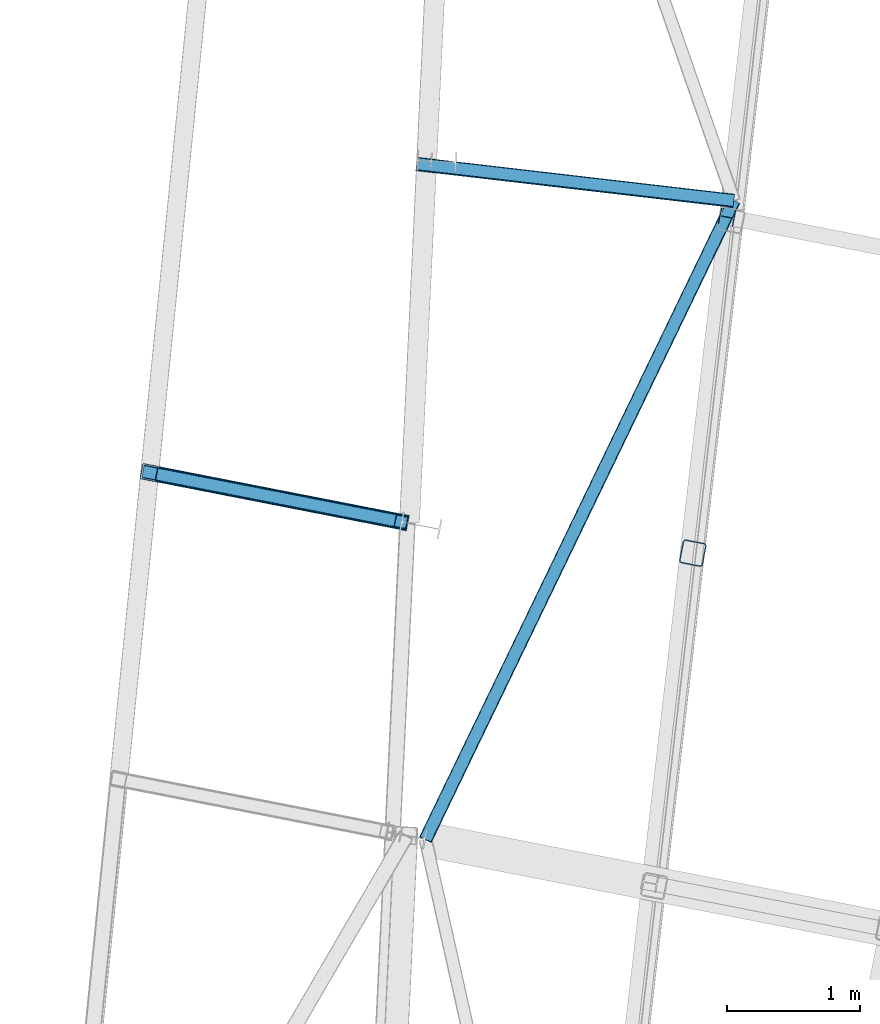
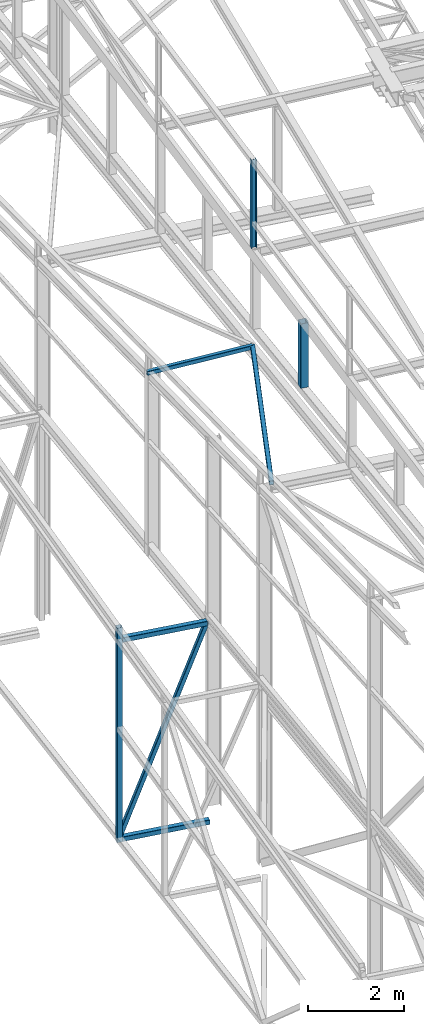
# One storey, part 67 of 215: 7 beams, 1 member, 8 elements without a shape of their own.
"""IFC2X3 building model written with IfcOpenShell, lengths in millimetres."""

import ifcopenshell
import ifcopenshell.guid

model = None  # the IFC model being written
_history = None  # IfcOwnerHistory: only IFC2X3 demands one
_inside = {}  # id of a spatial element -> (the spatial element, [elements in it])
_under = {}  # id of a project, library or spatial element -> (it, [spatial elements below it])
_declared = {}  # id of a project -> (the project, [libraries it declares])
_typed = {}  # id of a type object -> (the type object, [elements of that type])
_made_of = {}  # id of a material, layer set ... -> (it, [elements and type objects made of it])


def new_model(schema):
    """Start an empty IFC model of exactly this schema.

    Asked for "IFC4X3", IfcOpenShell would pick the latest addendum, in which some entities
    have other attributes; the version numbers below select the first issue.
    IFC2X3 requires an IfcOwnerHistory on every rooted entity: one is made here for all.
    """
    global model, _history
    if schema == "IFC4X3":
        model = ifcopenshell.file(schema_version=(4, 3, 0, 0))
    else:
        model = ifcopenshell.file(schema=schema)
    _inside.clear()
    _under.clear()
    _declared.clear()
    _typed.clear()
    _made_of.clear()
    _history = None
    if model.schema == "IFC2X3":
        org = make("IfcOrganization", Name="unknown")
        user = make(
            "IfcPersonAndOrganization",
            ThePerson=make("IfcPerson", FamilyName="unknown"),
            TheOrganization=org,
        )
        app = make(
            "IfcApplication",
            ApplicationDeveloper=org,
            Version="unknown",
            ApplicationFullName="unknown",
            ApplicationIdentifier="unknown",
        )
        _history = make(
            "IfcOwnerHistory",
            OwningUser=user,
            OwningApplication=app,
            ChangeAction="ADDED",
            CreationDate=0,
        )
    return model


def make(cls, **values):
    """One entity of the class cls with the attributes given. An attribute that is None is left unset."""
    return model.create_entity(
        cls, **{name: value for name, value in values.items() if value is not None}
    )


def rooted(cls, **values):
    """An entity with a GlobalId (a new one), such as an element, a storey or a relation."""
    return make(cls, GlobalId=ifcopenshell.guid.new(), OwnerHistory=_history, **values)


def si_unit(unit_type, name, prefix=None):
    """IfcSIUnit, for example si_unit("LENGTHUNIT", "METRE", prefix="MILLI")."""
    return make("IfcSIUnit", UnitType=unit_type, Prefix=prefix, Name=name)


def assignment(units):
    """IfcUnitAssignment: the units of a project."""
    return None if units is None else make("IfcUnitAssignment", Units=units)


def point(xyz):
    """IfcCartesianPoint."""
    return None if xyz is None else make("IfcCartesianPoint", Coordinates=xyz)


def direction(xyz):
    """IfcDirection."""
    return None if xyz is None else make("IfcDirection", DirectionRatios=xyz)


def frame(location, z_axis=None, x_axis=None):
    """IfcAxis2Placement3D, a coordinate frame: its origin and axes. An axis left out is left unset."""
    return make(
        "IfcAxis2Placement3D",
        Location=point(location),
        Axis=direction(z_axis),
        RefDirection=direction(x_axis),
    )


def frame_2d(location, x_axis=None):
    """IfcAxis2Placement2D, a coordinate frame in the plane: its origin and x axis."""
    return make(
        "IfcAxis2Placement2D", Location=point(location), RefDirection=direction(x_axis)
    )


def origin_with_axes():
    """The frame at (0, 0, 0) with the z axis (0, 0, 1) and the x axis (1, 0, 0) written out."""
    return frame((0.0, 0.0, 0.0), z_axis=(0.0, 0.0, 1.0), x_axis=(1.0, 0.0, 0.0))


def origin_2d_with_axis():
    """The frame at (0, 0) in the plane with the x axis (1, 0) written out."""
    return frame_2d((0.0, 0.0), x_axis=(1.0, 0.0))


def place(relative_to, where):
    """IfcLocalPlacement: puts the frame where relative to a parent placement (None: the world)."""
    return make(
        "IfcLocalPlacement", PlacementRelTo=relative_to, RelativePlacement=where
    )


def context(
    kind, dimensions, precision=None, world=None, true_north=None, identifier=None
):
    """IfcGeometricRepresentationContext, for example the 3D "Model" context."""
    return make(
        "IfcGeometricRepresentationContext",
        ContextIdentifier=identifier,
        ContextType=kind,
        CoordinateSpaceDimension=dimensions,
        Precision=precision,
        WorldCoordinateSystem=world,
        TrueNorth=true_north,
    )


def subcontext(parent, identifier, kind, view, scale=None):
    """IfcGeometricRepresentationSubContext, for example "Body" below "Model"."""
    return make(
        "IfcGeometricRepresentationSubContext",
        ContextIdentifier=identifier,
        ContextType=kind,
        ParentContext=parent,
        TargetScale=scale,
        TargetView=view,
    )


def project(units=None, contexts=None):
    """IfcProject with its units and contexts."""
    return rooted(
        "IfcProject",
        Name="project",
        RepresentationContexts=contexts,
        UnitsInContext=assignment(units),
    )


def spatial(cls, under=None, at=None, **own):
    """A site, building, storey or space (cls), placed at a placement, below another one or the project."""
    s = rooted(cls, ObjectPlacement=at, **own)
    if under is not None:
        _under.setdefault(under.id(), (under, []))[1].append(s)
    return s


def profile(cls, at=None, kind="AREA", **sizes):
    """A parametric profile (cls). Its sizes go by their IFC names, for example OverallWidth=200.0."""
    return make(cls, ProfileType=kind, Position=at, **sizes)


def hollow_rectangle(**sizes):
    """IfcRectangleHollowProfileDef."""
    return profile("IfcRectangleHollowProfileDef", **sizes)


def i_section(**sizes):
    """IfcIShapeProfileDef."""
    return profile("IfcIShapeProfileDef", **sizes)


def extrude(swept, where, along, depth):
    """IfcExtrudedAreaSolid: the profile swept, set in the frame where, extruded along a direction by depth."""
    return make(
        "IfcExtrudedAreaSolid",
        SweptArea=swept,
        Position=where,
        ExtrudedDirection=direction(along),
        Depth=depth,
    )


def clip(a, b, op="DIFFERENCE"):
    """IfcBooleanClippingResult: the solid a cut by the half space b."""
    return make(
        "IfcBooleanClippingResult", Operator=op, FirstOperand=a, SecondOperand=b
    )


def halfspace(plane, agree):
    """IfcHalfSpaceSolid: all space on one side of the plane z = 0 of the frame plane."""
    return make(
        "IfcHalfSpaceSolid",
        BaseSurface=make("IfcPlane", Position=plane),
        AgreementFlag=agree,
    )


def shape(context_of_items, identifier, shape_type, items):
    """IfcShapeRepresentation: the items that make up one representation, for example the "Body"."""
    return make(
        "IfcShapeRepresentation",
        ContextOfItems=context_of_items,
        RepresentationIdentifier=identifier,
        RepresentationType=shape_type,
        Items=items,
    )


def material(Name=None, Category=None):
    """IfcMaterial."""
    return make("IfcMaterial", Name=Name, Category=Category)


def made_of(thing, what):
    """Note that an element or type object is made of a material, layer set ...; save() writes the relation."""
    if what is not None:
        _made_of.setdefault(what.id(), (what, []))[1].append(thing)
    return thing


def type_object(cls, material=None, **own):
    """A type object (cls), such as IfcWallType, which elements share."""
    return made_of(rooted(cls, **own), material)


def element(
    cls,
    number,
    at=None,
    inside=None,
    cuts=None,
    type_object=None,
    material=None,
    context=None,
    identifier="Body",
    shape_type=None,
    held_by="IfcProductDefinitionShape",
    body=None,
    shapes=None,
    **own,
):
    """One element of the class cls, such as IfcWall. Its Tag is "e" and its number.

    at: its placement. inside: the storey or other place that contains it. cuts: it is an
    opening in that element (IfcRelVoidsElement). A single representation is given by context,
    identifier, shape_type and body (its items); several are given by shapes. held_by: the class
    of the entity that holds the representations. save() writes the other relations.
    """
    e = rooted(cls, Tag="e%d" % number, ObjectPlacement=at, **own)
    if body is not None:
        shapes = [shape(context, identifier, shape_type, body)]
    if shapes is not None:
        e.Representation = make(held_by, Representations=shapes)
    if inside is not None:
        _inside.setdefault(inside.id(), (inside, []))[1].append(e)
    if cuts is not None:
        rooted(
            "IfcRelVoidsElement", RelatingBuildingElement=cuts, RelatedOpeningElement=e
        )
    if type_object is not None:
        _typed.setdefault(type_object.id(), (type_object, []))[1].append(e)
    return made_of(e, material)


def aggregate(whole, parts):
    """IfcRelAggregates: a whole, such as a stair, and the parts it consists of."""
    return rooted("IfcRelAggregates", RelatingObject=whole, RelatedObjects=parts)


def save(model, path):
    """Write the relations noted so far, then the file.

    IfcRelAggregates (storeys below a building ...), IfcRelContainedInSpatialStructure (elements
    in a storey), IfcRelDefinesByType, IfcRelAssociatesMaterial and IfcRelDeclares: one each for
    every whole, place, type object, material and project.
    """
    for whole, parts in _under.values():
        aggregate(whole, parts)
    for where, things in _inside.values():
        rooted(
            "IfcRelContainedInSpatialStructure",
            RelatedElements=things,
            RelatingStructure=where,
        )
    for kind, things in _typed.values():
        rooted("IfcRelDefinesByType", RelatedObjects=things, RelatingType=kind)
    for what, things in _made_of.values():
        rooted("IfcRelAssociatesMaterial", RelatedObjects=things, RelatingMaterial=what)
    for by, libraries in _declared.values():
        rooted("IfcRelDeclares", RelatingContext=by, RelatedDefinitions=libraries)
    model.write(path)


model = new_model("IFC2X3")

# Units and contexts
model_context = context("Model", 3, precision=1e-05, world=origin_with_axes())
body_context = subcontext(model_context, "Body", "Model", "MODEL_VIEW")
ifc_project = project(units=[si_unit("LENGTHUNIT", "METRE", prefix="MILLI"), si_unit("AREAUNIT", "SQUARE_METRE"), si_unit("VOLUMEUNIT", "CUBIC_METRE"), si_unit("MASSUNIT", "GRAM", prefix="KILO"), si_unit("TIMEUNIT", "SECOND"), si_unit("PLANEANGLEUNIT", "RADIAN"), si_unit("SOLIDANGLEUNIT", "STERADIAN"), si_unit("THERMODYNAMICTEMPERATUREUNIT", "DEGREE_CELSIUS"), si_unit("LUMINOUSINTENSITYUNIT", "LUMEN")], contexts=[model_context])

# Site, building, storey
site_placement = place(None, origin_with_axes())
site = spatial("IfcSite", under=ifc_project, at=site_placement, CompositionType="ELEMENT")
building_placement = place(site_placement, origin_with_axes())
building = spatial("IfcBuilding", under=site, at=building_placement, Name="Undefined", CompositionType="ELEMENT")
storey_placement = place(building_placement, origin_with_axes())
storey = spatial("IfcBuildingStorey", under=building, at=storey_placement, Name="Undefined", CompositionType="ELEMENT", Elevation=0.0)

# Assembly, beam
assembly_1_placement = place(storey_placement, origin_with_axes())
assembly_1 = element("IfcElementAssembly", 1, at=assembly_1_placement, inside=storey, Name="Steel Assembly", AssemblyPlace="NOTDEFINED", PredefinedType="RIGID_FRAME")
ifc_material = material(Name="STEEL/S275JR")
beam_type_1 = type_object("IfcBeamType", PredefinedType="NOTDEFINED")
beam_1_placement = place(assembly_1_placement, frame((36250.7928809844, 36894.7018046411, 5021.75625029921), z_axis=(-0.981422412140383, 0.191859451027444, 0.0), x_axis=(3.7800000005755e-07, 1.94399999970995e-06, -0.999999999998039)))
beam_1 = element("IfcBeam", 2, at=beam_1_placement, type_object=beam_type_1, material=ifc_material, Name="MONTANT", context=body_context, shape_type="SweptSolid", body=[
    extrude(hollow_rectangle(XDim=120.0, YDim=120.0, WallThickness=5.0, InnerFilletRadius=5.0, OuterFilletRadius=10.0, at=origin_2d_with_axis()), frame((5457.13475754329, -2.31118646862289e-18, -3.63797846628199e-12), z_axis=(-1.0, 0.0, 0.0), x_axis=(-6.93889390390723e-18, -1.0, -3.46944695195361e-18)), (0.0, 0.0, 1.0), 5457.1),
])
aggregate(assembly_1, [beam_1])

assembly_2_placement = place(storey_placement, origin_with_axes())
assembly_2 = element("IfcElementAssembly", 3, at=assembly_2_placement, inside=storey, Name="Steel Assembly", AssemblyPlace="NOTDEFINED", PredefinedType="RIGID_FRAME")
beam_2_placement = place(assembly_2_placement, frame((36309.6787913867, 36883.1906591495, 4690.29321998795), z_axis=(0.0, 0.0, 1.0), x_axis=(0.981420896076704, -0.191867206014994, 0.0)))
beam_2 = element("IfcBeam", 4, at=beam_2_placement, type_object=beam_type_1, material=ifc_material, Name="POUTRE", context=body_context, shape_type="SweptSolid", body=[
    extrude(hollow_rectangle(XDim=120.0, YDim=120.0, WallThickness=5.0, InnerFilletRadius=5.0, OuterFilletRadius=10.0, at=origin_2d_with_axis()), frame((1871.77856512388, 0.0, 0.0), z_axis=(-1.0, 0.0, 0.0), x_axis=(-6.93889390390723e-18, -1.0, -3.46944695195361e-18)), (0.0, 0.0, 1.0), 1871.8),
])
aggregate(assembly_2, [beam_2])

assembly_3_placement = place(storey_placement, origin_with_axes())
assembly_3 = element("IfcElementAssembly", 5, at=assembly_3_placement, inside=storey, Name="Steel Assembly", AssemblyPlace="NOTDEFINED", PredefinedType="RIGID_FRAME")
beam_3_placement = place(assembly_3_placement, frame((36309.6798461953, 36883.1985792828, -375.378507595192), z_axis=(0.0, 0.0, 1.0), x_axis=(0.981422409205525, -0.19185946604018, 1.89999991602007e-08)))
beam_3 = element("IfcBeam", 6, at=beam_3_placement, type_object=beam_type_1, material=ifc_material, Name="POUTRE", context=body_context, shape_type="SweptSolid", body=[
    extrude(hollow_rectangle(XDim=120.0, YDim=120.0, WallThickness=5.0, InnerFilletRadius=5.0, OuterFilletRadius=10.0, at=origin_2d_with_axis()), frame((1924.31509716234, 5.34104731875857e-14, 5.6843418860808e-14), z_axis=(-1.0, 0.0, 0.0), x_axis=(-6.93889390390723e-18, -1.0, -3.46944695195361e-18)), (0.0, 0.0, 1.0), 1924.3),
])
aggregate(assembly_3, [beam_3])

assembly_4_placement = place(storey_placement, origin_with_axes())
assembly_4 = element("IfcElementAssembly", 7, at=assembly_4_placement, inside=storey, Name="Steel Assembly", AssemblyPlace="NOTDEFINED", PredefinedType="RIGID_FRAME")
beam_type_2 = type_object("IfcBeamType", PredefinedType="NOTDEFINED")
beam_4_placement = place(assembly_4_placement, frame((38262.259027407, 39216.0740032617, 9368.14621177728), z_axis=(0.115203788960212, 0.992088860657365, -0.0498776459827747), x_axis=(0.993325216792512, -0.115347360975905, -6.30000004858045e-08)))
beam_4 = element("IfcBeam", 8, at=beam_4_placement, type_object=beam_type_2, material=ifc_material, context=body_context, shape_type="SweptSolid", body=[
    extrude(hollow_rectangle(XDim=100.0, YDim=100.0, WallThickness=5.0, InnerFilletRadius=5.0, OuterFilletRadius=10.0, at=origin_2d_with_axis()), frame((2403.47614066428, -1.81713378225441e-12, 3.34853861177903e-14), z_axis=(-1.0, 0.0, 0.0), x_axis=(-6.93889390390723e-18, -1.0, -3.46944695195361e-18)), (0.0, 0.0, 1.0), 2403.5),
])
aggregate(assembly_4, [beam_4])

assembly_5_placement = place(storey_placement, origin_with_axes())
assembly_5 = element("IfcElementAssembly", 9, at=assembly_5_placement, inside=storey, Name="Steel Assembly", AssemblyPlace="NOTDEFINED", PredefinedType="RIGID_FRAME")
beam_5_placement = place(assembly_5_placement, frame((40649.6922643613, 38938.8374652992, 9368.14615700809), z_axis=(0.900788612590412, -0.433950403802687, 0.0163377619925705), x_axis=(-0.434219730893964, -0.899573436780325, 0.047125970988492)))
beam_5 = element("IfcBeam", 10, at=beam_5_placement, type_object=beam_type_2, material=ifc_material, context=body_context, shape_type="SweptSolid", body=[
    extrude(hollow_rectangle(XDim=100.0, YDim=100.0, WallThickness=5.0, InnerFilletRadius=5.0, OuterFilletRadius=10.0, at=origin_2d_with_axis()), frame((5342.99829990424, -3.70744983317921e-14, 4.69224119511743e-14), z_axis=(-1.0, 0.0, 0.0), x_axis=(-6.93889390390723e-18, -1.0, -3.46944695195361e-18)), (0.0, 0.0, 1.0), 5343.0),
])
aggregate(assembly_5, [beam_5])

# Assembly, member
assembly_6_placement = place(storey_placement, origin_with_axes())
assembly_6 = element("IfcElementAssembly", 11, at=assembly_6_placement, inside=storey, Name="Steel Assembly", AssemblyPlace="NOTDEFINED", PredefinedType="RIGID_FRAME")
member_type = type_object("IfcMemberType", PredefinedType="NOTDEFINED")
member_placement = place(assembly_6_placement, frame((36250.7948899859, 36894.7121336176, -345.378507585387), z_axis=(-0.916421876484706, 0.179150003899269, 0.357877381798769), x_axis=(0.351228357938975, -0.0686648469880693, 0.933768589837759)))
member = element("IfcMember", 12, at=member_placement, type_object=member_type, material=ifc_material, Name="POUTRE", context=body_context, shape_type="SweptSolid", body=[
    extrude(hollow_rectangle(XDim=100.0, YDim=100.0, WallThickness=5.0, InnerFilletRadius=5.0, OuterFilletRadius=10.0, at=origin_2d_with_axis()), frame((5397.85477917826, -3.28143983663216e-14, -3.63797880709171e-12), z_axis=(-1.0, 0.0, 0.0), x_axis=(-6.93889390390723e-18, -1.0, -3.46944695195361e-18)), (0.0, 0.0, 1.0), 5397.9),
])
aggregate(assembly_6, [member])

# Assembly, beam
assembly_7_placement = place(storey_placement, origin_with_axes())
assembly_7 = element("IfcElementAssembly", 13, at=assembly_7_placement, inside=storey, Name="Steel Assembly", AssemblyPlace="NOTDEFINED", PredefinedType="RIGID_FRAME")
beam_type_3 = type_object("IfcBeamType", PredefinedType="NOTDEFINED")
beam_6_placement = place(assembly_7_placement, frame((40341.6452446604, 36288.1287499349, 11724.6191089981), z_axis=(-0.981422412140383, 0.191859451027444, 0.0), x_axis=(0.0, 0.0, -1.0)))
beam_6 = element("IfcBeam", 14, at=beam_6_placement, type_object=beam_type_3, material=ifc_material, Name="MONTANT", context=body_context, shape_type="Clipping", body=[
    clip(extrude(hollow_rectangle(XDim=180.0, YDim=180.0, WallThickness=8.0, InnerFilletRadius=12.0, OuterFilletRadius=20.0, at=origin_2d_with_axis()), frame((1644.53155775925, 0.0, 0.0), z_axis=(-1.0, 0.0, 0.0), x_axis=(-6.93889390390723e-18, -1.0, -3.46944695195361e-18)), (0.0, 0.0, 1.0), 1644.5), halfspace(frame((1648.56430810146, -171.004364965731, 103.304420613003), z_axis=(-0.998757541180045, -0.0496840699304531, 0.00385579189483438), x_axis=(0.0, -0.0773735506072624, -0.997002173350904)), True)),
])
aggregate(assembly_7, [beam_6])

assembly_8_placement = place(storey_placement, origin_with_axes())
assembly_8 = element("IfcElementAssembly", 15, at=assembly_8_placement, inside=storey, Name="Steel Assembly", AssemblyPlace="NOTDEFINED", PredefinedType="RIGID_FRAME")
beam_type_4 = type_object("IfcBeamType", Name="HEA120", PredefinedType="NOTDEFINED")
beam_7_placement = place(assembly_8_placement, frame((40599.3776623625, 38816.1877530392, 14219.9969930826), z_axis=(0.981422409205525, -0.19185946604018, 1.89999991602007e-08), x_axis=(0.0, 0.0, -1.0)))
beam_7 = element("IfcBeam", 16, at=beam_7_placement, type_object=beam_type_4, material=ifc_material, ObjectType="HEA120", context=body_context, shape_type="SweptSolid", body=[
    extrude(i_section(OverallWidth=120.0, OverallDepth=114.0, WebThickness=5.0, FlangeThickness=8.0, FilletRadius=12.0, at=origin_2d_with_axis()), frame((2237.30710638012, -1.45519152357695e-11, 0.0), z_axis=(-1.0, 0.0, 0.0), x_axis=(-6.93889390390723e-18, -1.0, -3.46944695195361e-18)), (0.0, 0.0, 1.0), 2237.3),
])
aggregate(assembly_8, [beam_7])

save(model, "model.ifc")
